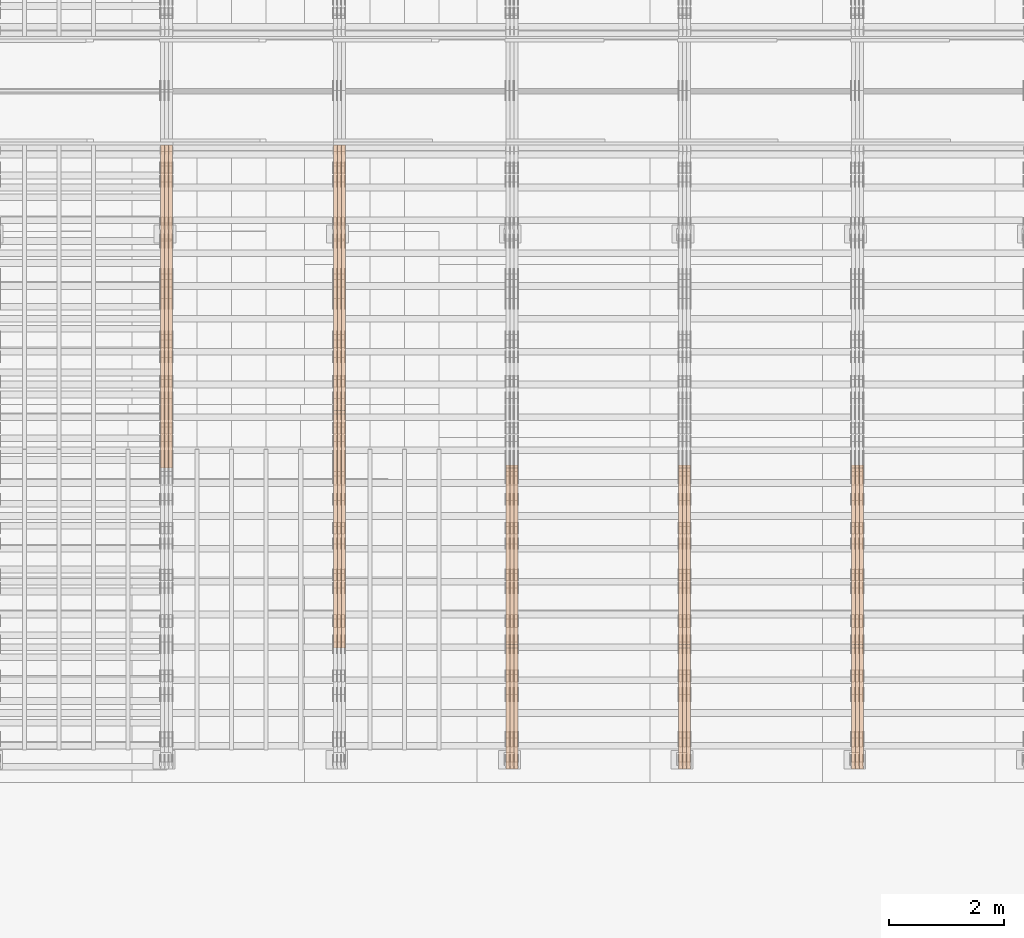
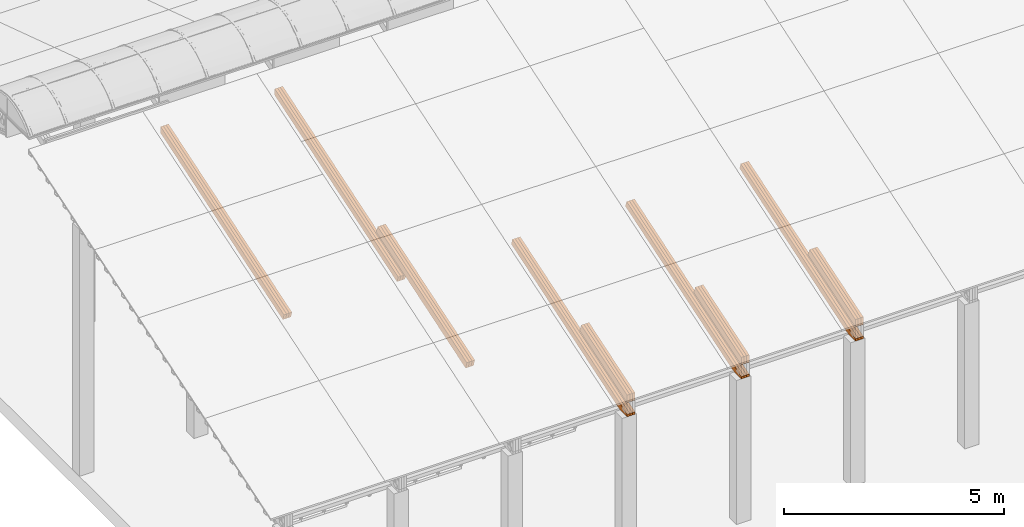
# One storey, part 12 of 385: 27 proxies.
"""IFC2X3 building model written with IfcOpenShell, lengths in millimetres."""

from ifc_helpers import new_model, entity, si_unit, converted_unit, derived_unit, direction, frame, origin, place, context, subcontext, project, spatial, polyline, outline, extrude, source, transform, mapped, material, type_object, type_shapes, element, save


model = new_model("IFC2X3")

# Units and contexts
model_context = context("Model", 3, precision=0.01, world=origin(), true_north=direction((6.12303176911189e-17, 1.0)))
body_context = subcontext(model_context, "Body", "Model", "MODEL_VIEW")
ifc_project = project(units=[si_unit("LENGTHUNIT", "METRE", prefix="MILLI"), si_unit("AREAUNIT", "SQUARE_METRE"), si_unit("VOLUMEUNIT", "CUBIC_METRE"), converted_unit("PLANEANGLEUNIT", "DEGREE", entity("IfcRatioMeasure", 0.0174532925199433), si_unit("PLANEANGLEUNIT", "RADIAN"), dimensions=[0, 0, 0, 0, 0, 0, 0]), si_unit("MASSUNIT", "GRAM", prefix="KILO"), derived_unit("MASSDENSITYUNIT", [(si_unit("MASSUNIT", "GRAM", prefix="KILO"), 1), (si_unit("LENGTHUNIT", "METRE"), -3)]), si_unit("TIMEUNIT", "SECOND"), si_unit("FREQUENCYUNIT", "HERTZ"), si_unit("THERMODYNAMICTEMPERATUREUNIT", "DEGREE_CELSIUS"), derived_unit("THERMALTRANSMITTANCEUNIT", [(si_unit("MASSUNIT", "GRAM", prefix="KILO"), 1), (si_unit("THERMODYNAMICTEMPERATUREUNIT", "KELVIN"), -1), (si_unit("TIMEUNIT", "SECOND"), -3)]), derived_unit("VOLUMETRICFLOWRATEUNIT", [(si_unit("LENGTHUNIT", "METRE"), 3), (si_unit("TIMEUNIT", "SECOND"), -1)]), si_unit("ELECTRICCURRENTUNIT", "AMPERE"), si_unit("ELECTRICVOLTAGEUNIT", "VOLT"), si_unit("POWERUNIT", "WATT"), si_unit("FORCEUNIT", "NEWTON", prefix="KILO"), si_unit("ILLUMINANCEUNIT", "LUX"), si_unit("LUMINOUSFLUXUNIT", "LUMEN"), si_unit("LUMINOUSINTENSITYUNIT", "CANDELA"), derived_unit("USERDEFINED", [(si_unit("MASSUNIT", "GRAM", prefix="KILO"), -1), (si_unit("LENGTHUNIT", "METRE"), -2), (si_unit("TIMEUNIT", "SECOND"), 3), (si_unit("LUMINOUSFLUXUNIT", "LUMEN"), 1)]), derived_unit("LINEARVELOCITYUNIT", [(si_unit("LENGTHUNIT", "METRE"), 1), (si_unit("TIMEUNIT", "SECOND"), -1)]), si_unit("PRESSUREUNIT", "PASCAL"), derived_unit("USERDEFINED", [(si_unit("LENGTHUNIT", "METRE"), -2), (si_unit("MASSUNIT", "GRAM", prefix="KILO"), 1), (si_unit("TIMEUNIT", "SECOND"), -2)])], contexts=[model_context])

# Site, building, storey
site_placement = place(None, origin())
site = spatial("IfcSite", under=ifc_project, at=site_placement, CompositionType="ELEMENT")
building_placement = place(site_placement, origin())
building = spatial("IfcBuilding", under=site, at=building_placement, CompositionType="ELEMENT")
storey_placement = place(building_placement, origin())
storey = spatial("IfcBuildingStorey", under=building, at=storey_placement, Name="Default", CompositionType="ELEMENT", Elevation=0.0)

# Proxies
ifc_material_1 = material(Name="IfcSurfaceStyle #180007")
building_element_proxy_type_1 = type_object("IfcBuildingElementProxyType", Name="T1-T3 180005", PredefinedType="NOTDEFINED", material=ifc_material_1)
shared_shape_1 = source(origin(), body_context, "Body", "SweptSolid", [
    extrude(outline(polyline([(-1085.54462735035, -97.5001496742589), (1117.22361141796, -97.5001496742589), (1117.22498157786, 97.5001496742589), (-1148.90396564547, 97.5001496742589), (-1085.54462735035, -97.5001496742589)])), frame((1117.22498157786, 97.5001496742589, 0.0), z_axis=(0.0, 0.0, 1.0), x_axis=(-1.0, 0.0, 0.0)), (0.0, 0.0, 1.0), 69.9999999999999),
])
type_shapes(building_element_proxy_type_1, [shared_shape_1])
proxy_1_placement = place(building_placement, frame((15385.0, 5095.216796875, 1095.23693847656), z_axis=(-1.0, 0.0, 0.0), x_axis=(0.0, -0.951056516295154, -0.309016994374948)))
element("IfcBuildingElementProxy", 1, at=proxy_1_placement, inside=storey, type_object=building_element_proxy_type_1, material=ifc_material_1, Name="T1-T3", context=body_context, shape_type="MappedRepresentation", body=[
    mapped(shared_shape_1, transform((0.0, 0.0, 0.0), scale=1.0)),
])
ifc_material_2 = material(Name="IfcSurfaceStyle #179950")
building_element_proxy_type_2 = type_object("IfcBuildingElementProxyType", Name="T1-T3 179948", PredefinedType="NOTDEFINED", material=ifc_material_2)
shared_shape_2 = source(origin(), body_context, "Body", "SweptSolid", [
    extrude(outline(polyline([(-1085.54462735035, -97.5001496742589), (1117.22361141796, -97.5001496742589), (1117.22498157786, 97.5001496742589), (-1148.90396564547, 97.5001496742589), (-1085.54462735035, -97.5001496742589)])), frame((1117.22498157786, 97.5001496742589, 0.0), z_axis=(0.0, 0.0, 1.0), x_axis=(-1.0, 0.0, 0.0)), (0.0, 0.0, 1.0), 69.9999999999999),
])
type_shapes(building_element_proxy_type_2, [shared_shape_2])
proxy_2_placement = place(building_placement, frame((15315.0, 5095.216796875, 1095.23693847656), z_axis=(-1.0, 0.0, 0.0), x_axis=(0.0, -0.951056516295154, -0.309016994374948)))
element("IfcBuildingElementProxy", 2, at=proxy_2_placement, inside=storey, type_object=building_element_proxy_type_2, material=ifc_material_2, Name="T1-T3", context=body_context, shape_type="MappedRepresentation", body=[
    mapped(shared_shape_2, transform((0.0, 0.0, 0.0), scale=1.0)),
])
ifc_material_3 = material(Name="IfcSurfaceStyle #179893")
building_element_proxy_type_3 = type_object("IfcBuildingElementProxyType", Name="T1-T3 179891", PredefinedType="NOTDEFINED", material=ifc_material_3)
shared_shape_3 = source(origin(), body_context, "Body", "SweptSolid", [
    extrude(outline(polyline([(-1085.54462735035, -97.5001496742589), (1117.22361141796, -97.5001496742589), (1117.22498157786, 97.5001496742589), (-1148.90396564547, 97.5001496742589), (-1085.54462735035, -97.5001496742589)])), frame((1117.22498157786, 97.5001496742589, 0.0), z_axis=(0.0, 0.0, 1.0), x_axis=(-1.0, 0.0, 0.0)), (0.0, 0.0, 1.0), 69.9999999999999),
])
type_shapes(building_element_proxy_type_3, [shared_shape_3])
proxy_3_placement = place(building_placement, frame((15245.0, 5095.216796875, 1095.23693847656), z_axis=(-1.0, 0.0, 0.0), x_axis=(0.0, -0.951056516295154, -0.309016994374948)))
element("IfcBuildingElementProxy", 3, at=proxy_3_placement, inside=storey, type_object=building_element_proxy_type_3, material=ifc_material_3, Name="T1-T3", context=body_context, shape_type="MappedRepresentation", body=[
    mapped(shared_shape_3, transform((0.0, 0.0, 0.0), scale=1.0)),
])
ifc_material_4 = material(Name="IfcSurfaceStyle #179323")
building_element_proxy_type_4 = type_object("IfcBuildingElementProxyType", Name="T1-B5 179321", PredefinedType="NOTDEFINED", material=ifc_material_4)
shared_shape_4 = source(origin(), body_context, "Body", "SweptSolid", [
    extrude(outline(polyline([(-3238.20553797979, -89.0131148793731), (1950.26357999126, -89.0131148793731), (2273.6227955316, 16.0525968934038), (2252.52438864378, 80.9868164326712), (-3238.20522618685, 80.9868164326712), (-3238.20553797979, -89.0131148793731)])), frame((2273.6227955316, 80.9869419088758, 0.0), z_axis=(0.0, 0.0, 1.0), x_axis=(-1.0, 0.0, 0.0)), (0.0, 0.0, 1.0), 69.9999999999997),
])
type_shapes(building_element_proxy_type_4, [shared_shape_4])
proxy_4_placement = place(building_placement, frame((15385.0, 2919.93418387161, 61.7562319586341), z_axis=(-1.0, 0.0, 0.0), x_axis=(0.0, 0.951056516295124, 0.309016994375039)))
element("IfcBuildingElementProxy", 4, at=proxy_4_placement, inside=storey, type_object=building_element_proxy_type_4, material=ifc_material_4, Name="T1-B5", context=body_context, shape_type="MappedRepresentation", body=[
    mapped(shared_shape_4, transform((0.0, 0.0, 0.0), scale=1.0)),
])
ifc_material_5 = material(Name="IfcSurfaceStyle #179257")
building_element_proxy_type_5 = type_object("IfcBuildingElementProxyType", Name="T1-B5 179255", PredefinedType="NOTDEFINED", material=ifc_material_5)
shared_shape_5 = source(origin(), body_context, "Body", "SweptSolid", [
    extrude(outline(polyline([(-3238.20553797979, -89.0131148793731), (1950.26357999126, -89.0131148793731), (2273.6227955316, 16.0525968934038), (2252.52438864378, 80.9868164326712), (-3238.20522618685, 80.9868164326712), (-3238.20553797979, -89.0131148793731)])), frame((2273.6227955316, 80.9869419088758, 0.0), z_axis=(0.0, 0.0, 1.0), x_axis=(-1.0, 0.0, 0.0)), (0.0, 0.0, 1.0), 69.9999999999997),
])
type_shapes(building_element_proxy_type_5, [shared_shape_5])
proxy_5_placement = place(building_placement, frame((15315.0, 2919.93418387161, 61.7562319586341), z_axis=(-1.0, 0.0, 0.0), x_axis=(0.0, 0.951056516295124, 0.309016994375039)))
element("IfcBuildingElementProxy", 5, at=proxy_5_placement, inside=storey, type_object=building_element_proxy_type_5, material=ifc_material_5, Name="T1-B5", context=body_context, shape_type="MappedRepresentation", body=[
    mapped(shared_shape_5, transform((0.0, 0.0, 0.0), scale=1.0)),
])
ifc_material_6 = material(Name="IfcSurfaceStyle #179191")
building_element_proxy_type_6 = type_object("IfcBuildingElementProxyType", Name="T1-B5 179189", PredefinedType="NOTDEFINED", material=ifc_material_6)
shared_shape_6 = source(origin(), body_context, "Body", "SweptSolid", [
    extrude(outline(polyline([(-3238.20553797979, -89.0131148793731), (1950.26357999126, -89.0131148793731), (2273.6227955316, 16.0525968934038), (2252.52438864378, 80.9868164326712), (-3238.20522618685, 80.9868164326712), (-3238.20553797979, -89.0131148793731)])), frame((2273.6227955316, 80.9869419088758, 0.0), z_axis=(0.0, 0.0, 1.0), x_axis=(-1.0, 0.0, 0.0)), (0.0, 0.0, 1.0), 69.9999999999997),
])
type_shapes(building_element_proxy_type_6, [shared_shape_6])
proxy_6_placement = place(building_placement, frame((15245.0, 2919.93418387161, 61.7562319586341), z_axis=(-1.0, 0.0, 0.0), x_axis=(0.0, 0.951056516295124, 0.309016994375039)))
element("IfcBuildingElementProxy", 6, at=proxy_6_placement, inside=storey, type_object=building_element_proxy_type_6, material=ifc_material_6, Name="T1-B5", context=body_context, shape_type="MappedRepresentation", body=[
    mapped(shared_shape_6, transform((0.0, 0.0, 0.0), scale=1.0)),
])
ifc_material_7 = material(Name="IfcSurfaceStyle #145575")
building_element_proxy_type_7 = type_object("IfcBuildingElementProxyType", Name="T1-T3 145573", PredefinedType="NOTDEFINED", material=ifc_material_7)
shared_shape_7 = source(origin(), body_context, "Body", "SweptSolid", [
    extrude(outline(polyline([(-1085.54462735035, -97.5001496742589), (1117.22361141796, -97.5001496742589), (1117.22498157786, 97.5001496742589), (-1148.90396564547, 97.5001496742589), (-1085.54462735035, -97.5001496742589)])), frame((1117.22498157786, 97.5001496742589, 0.0), z_axis=(0.0, 0.0, 1.0), x_axis=(-1.0, 0.0, 0.0)), (0.0, 0.0, 1.0), 69.9999999999999),
])
type_shapes(building_element_proxy_type_7, [shared_shape_7])
proxy_7_placement = place(building_placement, frame((12385.0, 5095.216796875, 1095.23693847656), z_axis=(-1.0, 0.0, 0.0), x_axis=(0.0, -0.951056516295154, -0.309016994374948)))
element("IfcBuildingElementProxy", 7, at=proxy_7_placement, inside=storey, type_object=building_element_proxy_type_7, material=ifc_material_7, Name="T1-T3", context=body_context, shape_type="MappedRepresentation", body=[
    mapped(shared_shape_7, transform((0.0, 0.0, 0.0), scale=1.0)),
])
ifc_material_8 = material(Name="IfcSurfaceStyle #145518")
building_element_proxy_type_8 = type_object("IfcBuildingElementProxyType", Name="T1-T3 145516", PredefinedType="NOTDEFINED", material=ifc_material_8)
shared_shape_8 = source(origin(), body_context, "Body", "SweptSolid", [
    extrude(outline(polyline([(-1085.54462735035, -97.5001496742589), (1117.22361141796, -97.5001496742589), (1117.22498157786, 97.5001496742589), (-1148.90396564547, 97.5001496742589), (-1085.54462735035, -97.5001496742589)])), frame((1117.22498157786, 97.5001496742589, 0.0), z_axis=(0.0, 0.0, 1.0), x_axis=(-1.0, 0.0, 0.0)), (0.0, 0.0, 1.0), 69.9999999999999),
])
type_shapes(building_element_proxy_type_8, [shared_shape_8])
proxy_8_placement = place(building_placement, frame((12315.0, 5095.216796875, 1095.23693847656), z_axis=(-1.0, 0.0, 0.0), x_axis=(0.0, -0.951056516295154, -0.309016994374948)))
element("IfcBuildingElementProxy", 8, at=proxy_8_placement, inside=storey, type_object=building_element_proxy_type_8, material=ifc_material_8, Name="T1-T3", context=body_context, shape_type="MappedRepresentation", body=[
    mapped(shared_shape_8, transform((0.0, 0.0, 0.0), scale=1.0)),
])
ifc_material_9 = material(Name="IfcSurfaceStyle #145461")
building_element_proxy_type_9 = type_object("IfcBuildingElementProxyType", Name="T1-T3 145459", PredefinedType="NOTDEFINED", material=ifc_material_9)
shared_shape_9 = source(origin(), body_context, "Body", "SweptSolid", [
    extrude(outline(polyline([(-1085.54462735035, -97.5001496742589), (1117.22361141796, -97.5001496742589), (1117.22498157786, 97.5001496742589), (-1148.90396564547, 97.5001496742589), (-1085.54462735035, -97.5001496742589)])), frame((1117.22498157786, 97.5001496742589, 0.0), z_axis=(0.0, 0.0, 1.0), x_axis=(-1.0, 0.0, 0.0)), (0.0, 0.0, 1.0), 69.9999999999999),
])
type_shapes(building_element_proxy_type_9, [shared_shape_9])
proxy_9_placement = place(building_placement, frame((12245.0, 5095.216796875, 1095.23693847656), z_axis=(-1.0, 0.0, 0.0), x_axis=(0.0, -0.951056516295154, -0.309016994374948)))
element("IfcBuildingElementProxy", 9, at=proxy_9_placement, inside=storey, type_object=building_element_proxy_type_9, material=ifc_material_9, Name="T1-T3", context=body_context, shape_type="MappedRepresentation", body=[
    mapped(shared_shape_9, transform((0.0, 0.0, 0.0), scale=1.0)),
])
ifc_material_10 = material(Name="IfcSurfaceStyle #144891")
building_element_proxy_type_10 = type_object("IfcBuildingElementProxyType", Name="T1-B5 144889", PredefinedType="NOTDEFINED", material=ifc_material_10)
shared_shape_10 = source(origin(), body_context, "Body", "SweptSolid", [
    extrude(outline(polyline([(-3238.20553797979, -89.0131148793731), (1950.26357999126, -89.0131148793731), (2273.6227955316, 16.0525968934038), (2252.52438864378, 80.9868164326712), (-3238.20522618685, 80.9868164326712), (-3238.20553797979, -89.0131148793731)])), frame((2273.6227955316, 80.9869419088758, 0.0), z_axis=(0.0, 0.0, 1.0), x_axis=(-1.0, 0.0, 0.0)), (0.0, 0.0, 1.0), 69.9999999999997),
])
type_shapes(building_element_proxy_type_10, [shared_shape_10])
proxy_10_placement = place(building_placement, frame((12385.0, 2919.93418387161, 61.7562319586341), z_axis=(-1.0, 0.0, 0.0), x_axis=(0.0, 0.951056516295124, 0.309016994375039)))
element("IfcBuildingElementProxy", 10, at=proxy_10_placement, inside=storey, type_object=building_element_proxy_type_10, material=ifc_material_10, Name="T1-B5", context=body_context, shape_type="MappedRepresentation", body=[
    mapped(shared_shape_10, transform((0.0, 0.0, 0.0), scale=1.0)),
])
ifc_material_11 = material(Name="IfcSurfaceStyle #144825")
building_element_proxy_type_11 = type_object("IfcBuildingElementProxyType", Name="T1-B5 144823", PredefinedType="NOTDEFINED", material=ifc_material_11)
shared_shape_11 = source(origin(), body_context, "Body", "SweptSolid", [
    extrude(outline(polyline([(-3238.20553797979, -89.0131148793731), (1950.26357999126, -89.0131148793731), (2273.6227955316, 16.0525968934038), (2252.52438864378, 80.9868164326712), (-3238.20522618685, 80.9868164326712), (-3238.20553797979, -89.0131148793731)])), frame((2273.6227955316, 80.9869419088758, 0.0), z_axis=(0.0, 0.0, 1.0), x_axis=(-1.0, 0.0, 0.0)), (0.0, 0.0, 1.0), 69.9999999999997),
])
type_shapes(building_element_proxy_type_11, [shared_shape_11])
proxy_11_placement = place(building_placement, frame((12315.0, 2919.93418387161, 61.7562319586341), z_axis=(-1.0, 0.0, 0.0), x_axis=(0.0, 0.951056516295124, 0.309016994375039)))
element("IfcBuildingElementProxy", 11, at=proxy_11_placement, inside=storey, type_object=building_element_proxy_type_11, material=ifc_material_11, Name="T1-B5", context=body_context, shape_type="MappedRepresentation", body=[
    mapped(shared_shape_11, transform((0.0, 0.0, 0.0), scale=1.0)),
])
ifc_material_12 = material(Name="IfcSurfaceStyle #144759")
building_element_proxy_type_12 = type_object("IfcBuildingElementProxyType", Name="T1-B5 144757", PredefinedType="NOTDEFINED", material=ifc_material_12)
shared_shape_12 = source(origin(), body_context, "Body", "SweptSolid", [
    extrude(outline(polyline([(-3238.20553797979, -89.0131148793731), (1950.26357999126, -89.0131148793731), (2273.6227955316, 16.0525968934038), (2252.52438864378, 80.9868164326712), (-3238.20522618685, 80.9868164326712), (-3238.20553797979, -89.0131148793731)])), frame((2273.6227955316, 80.9869419088758, 0.0), z_axis=(0.0, 0.0, 1.0), x_axis=(-1.0, 0.0, 0.0)), (0.0, 0.0, 1.0), 69.9999999999997),
])
type_shapes(building_element_proxy_type_12, [shared_shape_12])
proxy_12_placement = place(building_placement, frame((12245.0, 2919.93418387161, 61.7562319586341), z_axis=(-1.0, 0.0, 0.0), x_axis=(0.0, 0.951056516295124, 0.309016994375039)))
element("IfcBuildingElementProxy", 12, at=proxy_12_placement, inside=storey, type_object=building_element_proxy_type_12, material=ifc_material_12, Name="T1-B5", context=body_context, shape_type="MappedRepresentation", body=[
    mapped(shared_shape_12, transform((0.0, 0.0, 0.0), scale=1.0)),
])
ifc_material_13 = material(Name="IfcSurfaceStyle #111143")
building_element_proxy_type_13 = type_object("IfcBuildingElementProxyType", Name="T1-T3 111141", PredefinedType="NOTDEFINED", material=ifc_material_13)
shared_shape_13 = source(origin(), body_context, "Body", "SweptSolid", [
    extrude(outline(polyline([(-1085.54462735035, -97.5001496742589), (1117.22361141796, -97.5001496742589), (1117.22498157786, 97.5001496742589), (-1148.90396564547, 97.5001496742589), (-1085.54462735035, -97.5001496742589)])), frame((1117.22498157786, 97.5001496742589, 0.0), z_axis=(0.0, 0.0, 1.0), x_axis=(-1.0, 0.0, 0.0)), (0.0, 0.0, 1.0), 69.9999999999999),
])
type_shapes(building_element_proxy_type_13, [shared_shape_13])
proxy_13_placement = place(building_placement, frame((9385.0, 5095.216796875, 1095.23693847656), z_axis=(-1.0, 0.0, 0.0), x_axis=(0.0, -0.951056516295154, -0.309016994374948)))
element("IfcBuildingElementProxy", 13, at=proxy_13_placement, inside=storey, type_object=building_element_proxy_type_13, material=ifc_material_13, Name="T1-T3", context=body_context, shape_type="MappedRepresentation", body=[
    mapped(shared_shape_13, transform((0.0, 0.0, 0.0), scale=1.0)),
])
ifc_material_14 = material(Name="IfcSurfaceStyle #111086")
building_element_proxy_type_14 = type_object("IfcBuildingElementProxyType", Name="T1-T3 111084", PredefinedType="NOTDEFINED", material=ifc_material_14)
shared_shape_14 = source(origin(), body_context, "Body", "SweptSolid", [
    extrude(outline(polyline([(-1085.54462735035, -97.5001496742589), (1117.22361141796, -97.5001496742589), (1117.22498157786, 97.5001496742589), (-1148.90396564547, 97.5001496742589), (-1085.54462735035, -97.5001496742589)])), frame((1117.22498157786, 97.5001496742589, 0.0), z_axis=(0.0, 0.0, 1.0), x_axis=(-1.0, 0.0, 0.0)), (0.0, 0.0, 1.0), 69.9999999999999),
])
type_shapes(building_element_proxy_type_14, [shared_shape_14])
proxy_14_placement = place(building_placement, frame((9315.0, 5095.216796875, 1095.23693847656), z_axis=(-1.0, 0.0, 0.0), x_axis=(0.0, -0.951056516295154, -0.309016994374948)))
element("IfcBuildingElementProxy", 14, at=proxy_14_placement, inside=storey, type_object=building_element_proxy_type_14, material=ifc_material_14, Name="T1-T3", context=body_context, shape_type="MappedRepresentation", body=[
    mapped(shared_shape_14, transform((0.0, 0.0, 0.0), scale=1.0)),
])
ifc_material_15 = material(Name="IfcSurfaceStyle #111029")
building_element_proxy_type_15 = type_object("IfcBuildingElementProxyType", Name="T1-T3 111027", PredefinedType="NOTDEFINED", material=ifc_material_15)
shared_shape_15 = source(origin(), body_context, "Body", "SweptSolid", [
    extrude(outline(polyline([(-1085.54462735035, -97.5001496742589), (1117.22361141796, -97.5001496742589), (1117.22498157786, 97.5001496742589), (-1148.90396564547, 97.5001496742589), (-1085.54462735035, -97.5001496742589)])), frame((1117.22498157786, 97.5001496742589, 0.0), z_axis=(0.0, 0.0, 1.0), x_axis=(-1.0, 0.0, 0.0)), (0.0, 0.0, 1.0), 69.9999999999999),
])
type_shapes(building_element_proxy_type_15, [shared_shape_15])
proxy_15_placement = place(building_placement, frame((9245.0, 5095.216796875, 1095.23693847656), z_axis=(-1.0, 0.0, 0.0), x_axis=(0.0, -0.951056516295154, -0.309016994374948)))
element("IfcBuildingElementProxy", 15, at=proxy_15_placement, inside=storey, type_object=building_element_proxy_type_15, material=ifc_material_15, Name="T1-T3", context=body_context, shape_type="MappedRepresentation", body=[
    mapped(shared_shape_15, transform((0.0, 0.0, 0.0), scale=1.0)),
])
ifc_material_16 = material(Name="IfcSurfaceStyle #110459")
building_element_proxy_type_16 = type_object("IfcBuildingElementProxyType", Name="T1-B5 110457", PredefinedType="NOTDEFINED", material=ifc_material_16)
shared_shape_16 = source(origin(), body_context, "Body", "SweptSolid", [
    extrude(outline(polyline([(-3238.20553797979, -89.0131148793731), (1950.26357999126, -89.0131148793731), (2273.6227955316, 16.0525968934038), (2252.52438864378, 80.9868164326712), (-3238.20522618685, 80.9868164326712), (-3238.20553797979, -89.0131148793731)])), frame((2273.6227955316, 80.9869419088758, 0.0), z_axis=(0.0, 0.0, 1.0), x_axis=(-1.0, 0.0, 0.0)), (0.0, 0.0, 1.0), 69.9999999999997),
])
type_shapes(building_element_proxy_type_16, [shared_shape_16])
proxy_16_placement = place(building_placement, frame((9385.0, 2919.93418387161, 61.7562319586341), z_axis=(-1.0, 0.0, 0.0), x_axis=(0.0, 0.951056516295124, 0.309016994375039)))
element("IfcBuildingElementProxy", 16, at=proxy_16_placement, inside=storey, type_object=building_element_proxy_type_16, material=ifc_material_16, Name="T1-B5", context=body_context, shape_type="MappedRepresentation", body=[
    mapped(shared_shape_16, transform((0.0, 0.0, 0.0), scale=1.0)),
])
ifc_material_17 = material(Name="IfcSurfaceStyle #110393")
building_element_proxy_type_17 = type_object("IfcBuildingElementProxyType", Name="T1-B5 110391", PredefinedType="NOTDEFINED", material=ifc_material_17)
shared_shape_17 = source(origin(), body_context, "Body", "SweptSolid", [
    extrude(outline(polyline([(-3238.20553797979, -89.0131148793731), (1950.26357999126, -89.0131148793731), (2273.6227955316, 16.0525968934038), (2252.52438864378, 80.9868164326712), (-3238.20522618685, 80.9868164326712), (-3238.20553797979, -89.0131148793731)])), frame((2273.6227955316, 80.9869419088758, 0.0), z_axis=(0.0, 0.0, 1.0), x_axis=(-1.0, 0.0, 0.0)), (0.0, 0.0, 1.0), 69.9999999999997),
])
type_shapes(building_element_proxy_type_17, [shared_shape_17])
proxy_17_placement = place(building_placement, frame((9315.0, 2919.93418387161, 61.7562319586341), z_axis=(-1.0, 0.0, 0.0), x_axis=(0.0, 0.951056516295124, 0.309016994375039)))
element("IfcBuildingElementProxy", 17, at=proxy_17_placement, inside=storey, type_object=building_element_proxy_type_17, material=ifc_material_17, Name="T1-B5", context=body_context, shape_type="MappedRepresentation", body=[
    mapped(shared_shape_17, transform((0.0, 0.0, 0.0), scale=1.0)),
])
ifc_material_18 = material(Name="IfcSurfaceStyle #110327")
building_element_proxy_type_18 = type_object("IfcBuildingElementProxyType", Name="T1-B5 110325", PredefinedType="NOTDEFINED", material=ifc_material_18)
shared_shape_18 = source(origin(), body_context, "Body", "SweptSolid", [
    extrude(outline(polyline([(-3238.20553797979, -89.0131148793731), (1950.26357999126, -89.0131148793731), (2273.6227955316, 16.0525968934038), (2252.52438864378, 80.9868164326712), (-3238.20522618685, 80.9868164326712), (-3238.20553797979, -89.0131148793731)])), frame((2273.6227955316, 80.9869419088758, 0.0), z_axis=(0.0, 0.0, 1.0), x_axis=(-1.0, 0.0, 0.0)), (0.0, 0.0, 1.0), 69.9999999999997),
])
type_shapes(building_element_proxy_type_18, [shared_shape_18])
proxy_18_placement = place(building_placement, frame((9245.0, 2919.93418387161, 61.7562319586341), z_axis=(-1.0, 0.0, 0.0), x_axis=(0.0, 0.951056516295124, 0.309016994375039)))
element("IfcBuildingElementProxy", 18, at=proxy_18_placement, inside=storey, type_object=building_element_proxy_type_18, material=ifc_material_18, Name="T1-B5", context=body_context, shape_type="MappedRepresentation", body=[
    mapped(shared_shape_18, transform((0.0, 0.0, 0.0), scale=1.0)),
])
ifc_material_19 = material(Name="IfcSurfaceStyle #76540")
building_element_proxy_type_19 = type_object("IfcBuildingElementProxyType", Name="T1-T2 76538", PredefinedType="NOTDEFINED", material=ifc_material_19)
shared_shape_19 = source(origin(), body_context, "Body", "SweptSolid", [
    extrude(outline(polyline([(-2137.04475371072, -97.5001541485635), (2137.04431231695, -97.5001541485635), (2137.0438249446, 97.5001541485636), (-2137.04338355082, 97.5001541485635), (-2137.04475371072, -97.5001541485635)])), frame((2137.04431231695, 97.5003268035489, 0.0), z_axis=(0.0, 0.0, 1.0), x_axis=(-1.0, 0.0, 0.0)), (0.0, 0.0, 1.0), 69.9999999999997),
])
type_shapes(building_element_proxy_type_19, [shared_shape_19])
proxy_19_placement = place(building_placement, frame((6385.0, 9160.11575124698, 2416.00267194857), z_axis=(-1.0, 0.0, 0.0), x_axis=(0.0, -0.951056516295154, -0.309016994374948)))
element("IfcBuildingElementProxy", 19, at=proxy_19_placement, inside=storey, type_object=building_element_proxy_type_19, material=ifc_material_19, Name="T1-T2", context=body_context, shape_type="MappedRepresentation", body=[
    mapped(shared_shape_19, transform((0.0, 0.0, 0.0), scale=1.0)),
])
ifc_material_20 = material(Name="IfcSurfaceStyle #76483")
building_element_proxy_type_20 = type_object("IfcBuildingElementProxyType", Name="T1-T2 76481", PredefinedType="NOTDEFINED", material=ifc_material_20)
shared_shape_20 = source(origin(), body_context, "Body", "SweptSolid", [
    extrude(outline(polyline([(-2137.04475371072, -97.5001541485635), (2137.04431231695, -97.5001541485635), (2137.0438249446, 97.5001541485636), (-2137.04338355082, 97.5001541485635), (-2137.04475371072, -97.5001541485635)])), frame((2137.04431231695, 97.5003268035489, 0.0), z_axis=(0.0, 0.0, 1.0), x_axis=(-1.0, 0.0, 0.0)), (0.0, 0.0, 1.0), 69.9999999999997),
])
type_shapes(building_element_proxy_type_20, [shared_shape_20])
proxy_20_placement = place(building_placement, frame((6315.0, 9160.11575124698, 2416.00267194857), z_axis=(-1.0, 0.0, 0.0), x_axis=(0.0, -0.951056516295154, -0.309016994374948)))
element("IfcBuildingElementProxy", 20, at=proxy_20_placement, inside=storey, type_object=building_element_proxy_type_20, material=ifc_material_20, Name="T1-T2", context=body_context, shape_type="MappedRepresentation", body=[
    mapped(shared_shape_20, transform((0.0, 0.0, 0.0), scale=1.0)),
])
ifc_material_21 = material(Name="IfcSurfaceStyle #76426")
building_element_proxy_type_21 = type_object("IfcBuildingElementProxyType", Name="T1-T2 76424", PredefinedType="NOTDEFINED", material=ifc_material_21)
shared_shape_21 = source(origin(), body_context, "Body", "SweptSolid", [
    extrude(outline(polyline([(-2137.04475371072, -97.5001541485635), (2137.04431231695, -97.5001541485635), (2137.0438249446, 97.5001541485636), (-2137.04338355082, 97.5001541485635), (-2137.04475371072, -97.5001541485635)])), frame((2137.04431231695, 97.5003268035489, 0.0), z_axis=(0.0, 0.0, 1.0), x_axis=(-1.0, 0.0, 0.0)), (0.0, 0.0, 1.0), 69.9999999999997),
])
type_shapes(building_element_proxy_type_21, [shared_shape_21])
proxy_21_placement = place(building_placement, frame((6245.0, 9160.11575124698, 2416.00267194857), z_axis=(-1.0, 0.0, 0.0), x_axis=(0.0, -0.951056516295154, -0.309016994374948)))
element("IfcBuildingElementProxy", 21, at=proxy_21_placement, inside=storey, type_object=building_element_proxy_type_21, material=ifc_material_21, Name="T1-T2", context=body_context, shape_type="MappedRepresentation", body=[
    mapped(shared_shape_21, transform((0.0, 0.0, 0.0), scale=1.0)),
])
ifc_material_22 = material(Name="IfcSurfaceStyle #76198")
building_element_proxy_type_22 = type_object("IfcBuildingElementProxyType", Name="T1-B4 76196", PredefinedType="NOTDEFINED", material=ifc_material_22)
shared_shape_22 = source(origin(), body_context, "Body", "SweptSolid", [
    extrude(outline(polyline([(-2912.13310129284, -85.0000958683222), (2939.75111293783, -85.0000958683222), (2939.75142473078, 85.0000958683222), (-2967.36943637577, 85.0000958683222), (-2912.13310129284, -85.0000958683222)])), frame((2939.75142473078, 85.0000958683222, 0.0), z_axis=(0.0, 0.0, 1.0), x_axis=(-1.0, 0.0, 0.0)), (0.0, 0.0, 1.0), 69.9999999999996),
])
type_shapes(building_element_proxy_type_22, [shared_shape_22])
proxy_22_placement = place(building_placement, frame((6385.0, 8161.994140625, 1765.00476074219), z_axis=(-1.0, 0.0, 0.0), x_axis=(0.0, 0.951056516295124, 0.309016994375039)))
element("IfcBuildingElementProxy", 22, at=proxy_22_placement, inside=storey, type_object=building_element_proxy_type_22, material=ifc_material_22, Name="T1-B4", context=body_context, shape_type="MappedRepresentation", body=[
    mapped(shared_shape_22, transform((0.0, 0.0, 0.0), scale=1.0)),
])
ifc_material_23 = material(Name="IfcSurfaceStyle #76141")
building_element_proxy_type_23 = type_object("IfcBuildingElementProxyType", Name="T1-B4 76139", PredefinedType="NOTDEFINED", material=ifc_material_23)
shared_shape_23 = source(origin(), body_context, "Body", "SweptSolid", [
    extrude(outline(polyline([(-2912.13310129284, -85.0000958683222), (2939.75111293783, -85.0000958683222), (2939.75142473078, 85.0000958683222), (-2967.36943637577, 85.0000958683222), (-2912.13310129284, -85.0000958683222)])), frame((2939.75142473078, 85.0000958683222, 0.0), z_axis=(0.0, 0.0, 1.0), x_axis=(-1.0, 0.0, 0.0)), (0.0, 0.0, 1.0), 69.9999999999996),
])
type_shapes(building_element_proxy_type_23, [shared_shape_23])
proxy_23_placement = place(building_placement, frame((6315.0, 8161.994140625, 1765.00476074219), z_axis=(-1.0, 0.0, 0.0), x_axis=(0.0, 0.951056516295124, 0.309016994375039)))
element("IfcBuildingElementProxy", 23, at=proxy_23_placement, inside=storey, type_object=building_element_proxy_type_23, material=ifc_material_23, Name="T1-B4", context=body_context, shape_type="MappedRepresentation", body=[
    mapped(shared_shape_23, transform((0.0, 0.0, 0.0), scale=1.0)),
])
ifc_material_24 = material(Name="IfcSurfaceStyle #76084")
building_element_proxy_type_24 = type_object("IfcBuildingElementProxyType", Name="T1-B4 76082", PredefinedType="NOTDEFINED", material=ifc_material_24)
shared_shape_24 = source(origin(), body_context, "Body", "SweptSolid", [
    extrude(outline(polyline([(-2912.13310129284, -85.0000958683222), (2939.75111293783, -85.0000958683222), (2939.75142473078, 85.0000958683222), (-2967.36943637577, 85.0000958683222), (-2912.13310129284, -85.0000958683222)])), frame((2939.75142473078, 85.0000958683222, 0.0), z_axis=(0.0, 0.0, 1.0), x_axis=(-1.0, 0.0, 0.0)), (0.0, 0.0, 1.0), 69.9999999999996),
])
type_shapes(building_element_proxy_type_24, [shared_shape_24])
proxy_24_placement = place(building_placement, frame((6245.0, 8161.994140625, 1765.00476074219), z_axis=(-1.0, 0.0, 0.0), x_axis=(0.0, 0.951056516295124, 0.309016994375039)))
element("IfcBuildingElementProxy", 24, at=proxy_24_placement, inside=storey, type_object=building_element_proxy_type_24, material=ifc_material_24, Name="T1-B4", context=body_context, shape_type="MappedRepresentation", body=[
    mapped(shared_shape_24, transform((0.0, 0.0, 0.0), scale=1.0)),
])
ifc_material_25 = material(Name="IfcSurfaceStyle #41766")
building_element_proxy_type_25 = type_object("IfcBuildingElementProxyType", Name="T1-B4 41764", PredefinedType="NOTDEFINED", material=ifc_material_25)
shared_shape_25 = source(origin(), body_context, "Body", "SweptSolid", [
    extrude(outline(polyline([(-2912.13310129284, -85.0000958683222), (2939.75111293783, -85.0000958683222), (2939.75142473078, 85.0000958683222), (-2967.36943637577, 85.0000958683222), (-2912.13310129284, -85.0000958683222)])), frame((2939.75142473078, 85.0000958683222, 0.0), z_axis=(0.0, 0.0, 1.0), x_axis=(-1.0, 0.0, 0.0)), (0.0, 0.0, 1.0), 69.9999999999996),
])
type_shapes(building_element_proxy_type_25, [shared_shape_25])
proxy_25_placement = place(building_placement, frame((3385.0, 8161.994140625, 1765.00476074219), z_axis=(-1.0, 0.0, 0.0), x_axis=(0.0, 0.951056516295124, 0.309016994375039)))
element("IfcBuildingElementProxy", 25, at=proxy_25_placement, inside=storey, type_object=building_element_proxy_type_25, material=ifc_material_25, Name="T1-B4", context=body_context, shape_type="MappedRepresentation", body=[
    mapped(shared_shape_25, transform((0.0, 0.0, 0.0), scale=1.0)),
])
ifc_material_26 = material(Name="IfcSurfaceStyle #41709")
building_element_proxy_type_26 = type_object("IfcBuildingElementProxyType", Name="T1-B4 41707", PredefinedType="NOTDEFINED", material=ifc_material_26)
shared_shape_26 = source(origin(), body_context, "Body", "SweptSolid", [
    extrude(outline(polyline([(-2912.13310129284, -85.0000958683222), (2939.75111293783, -85.0000958683222), (2939.75142473078, 85.0000958683222), (-2967.36943637577, 85.0000958683222), (-2912.13310129284, -85.0000958683222)])), frame((2939.75142473078, 85.0000958683222, 0.0), z_axis=(0.0, 0.0, 1.0), x_axis=(-1.0, 0.0, 0.0)), (0.0, 0.0, 1.0), 69.9999999999996),
])
type_shapes(building_element_proxy_type_26, [shared_shape_26])
proxy_26_placement = place(building_placement, frame((3315.0, 8161.994140625, 1765.00476074219), z_axis=(-1.0, 0.0, 0.0), x_axis=(0.0, 0.951056516295124, 0.309016994375039)))
element("IfcBuildingElementProxy", 26, at=proxy_26_placement, inside=storey, type_object=building_element_proxy_type_26, material=ifc_material_26, Name="T1-B4", context=body_context, shape_type="MappedRepresentation", body=[
    mapped(shared_shape_26, transform((0.0, 0.0, 0.0), scale=1.0)),
])
ifc_material_27 = material(Name="IfcSurfaceStyle #41652")
building_element_proxy_type_27 = type_object("IfcBuildingElementProxyType", Name="T1-B4 41650", PredefinedType="NOTDEFINED", material=ifc_material_27)
shared_shape_27 = source(origin(), body_context, "Body", "SweptSolid", [
    extrude(outline(polyline([(-2912.13310129284, -85.0000958683222), (2939.75111293783, -85.0000958683222), (2939.75142473078, 85.0000958683222), (-2967.36943637577, 85.0000958683222), (-2912.13310129284, -85.0000958683222)])), frame((2939.75142473078, 85.0000958683222, 0.0), z_axis=(0.0, 0.0, 1.0), x_axis=(-1.0, 0.0, 0.0)), (0.0, 0.0, 1.0), 69.9999999999996),
])
type_shapes(building_element_proxy_type_27, [shared_shape_27])
proxy_27_placement = place(building_placement, frame((3245.0, 8161.994140625, 1765.00476074219), z_axis=(-1.0, 0.0, 0.0), x_axis=(0.0, 0.951056516295124, 0.309016994375039)))
element("IfcBuildingElementProxy", 27, at=proxy_27_placement, inside=storey, type_object=building_element_proxy_type_27, material=ifc_material_27, Name="T1-B4", context=body_context, shape_type="MappedRepresentation", body=[
    mapped(shared_shape_27, transform((0.0, 0.0, 0.0), scale=1.0)),
])

save(model, "model.ifc")
